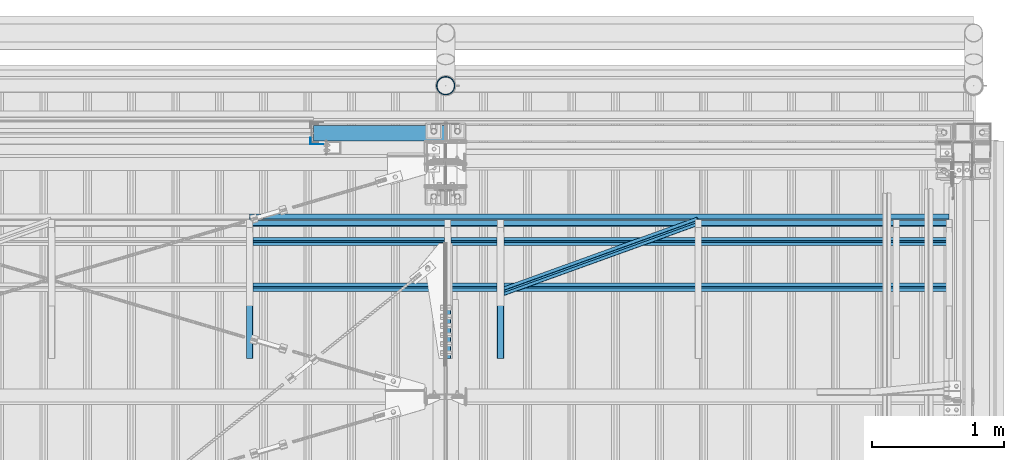
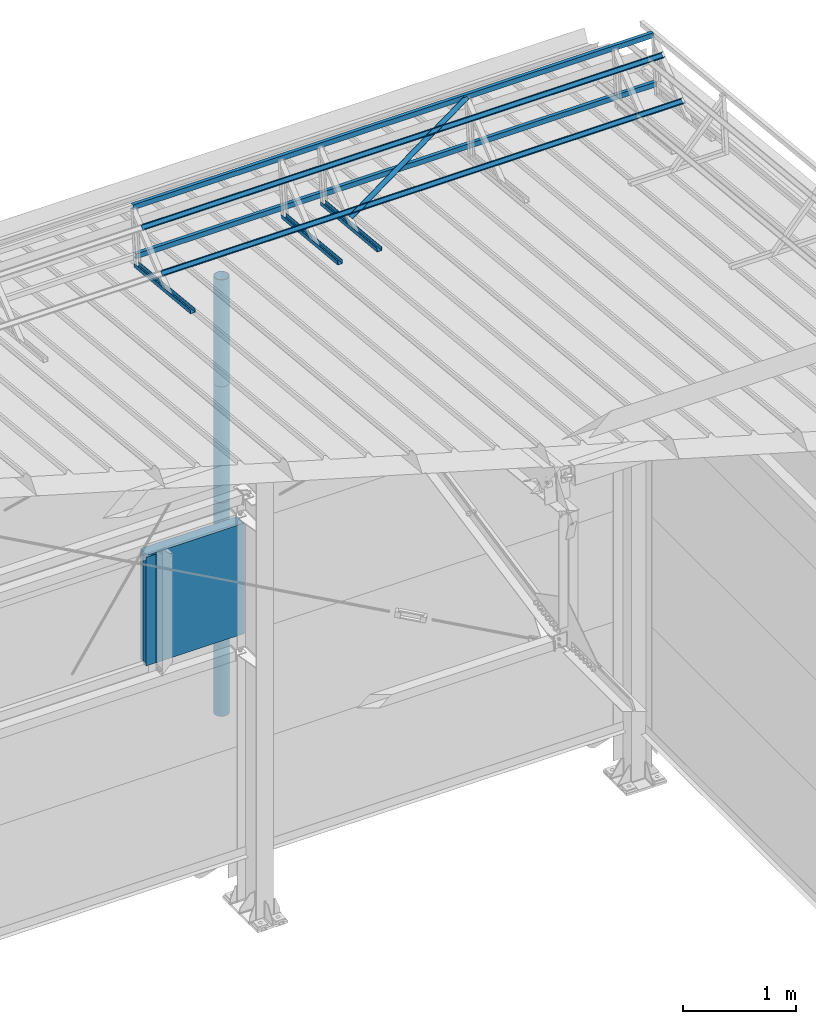
# One storey, part 79 of 709: 14 beams, 14 elements without a shape of their own.
"""IFC4 building model written with IfcOpenShell, lengths in millimetres."""

from ifc_helpers import new_model, si_unit, direction, frame, origin_with_axes, place, context, subcontext, project, spatial, line, indexed_curve, outline, extrude, material, element, aggregate, save


model = new_model("IFC4")

# Units and contexts
model_context = context("Model", 3, precision=0.2, world=origin_with_axes(), true_north=direction((0.0, 1.0)))
body_context = subcontext(model_context, "Body", "Model", "MODEL_VIEW")
ifc_project = project(units=[si_unit("LENGTHUNIT", "METRE", prefix="MILLI"), si_unit("AREAUNIT", "SQUARE_METRE"), si_unit("VOLUMEUNIT", "CUBIC_METRE"), si_unit("MASSUNIT", "GRAM", prefix="KILO"), si_unit("TIMEUNIT", "SECOND"), si_unit("PLANEANGLEUNIT", "RADIAN"), si_unit("SOLIDANGLEUNIT", "STERADIAN"), si_unit("THERMODYNAMICTEMPERATUREUNIT", "DEGREE_CELSIUS"), si_unit("LUMINOUSINTENSITYUNIT", "LUMEN")], contexts=[model_context])

# Site, building, storey
site_placement = place(None, origin_with_axes())
site = spatial("IfcSite", under=ifc_project, at=site_placement, CompositionType="ELEMENT")
building_placement = place(site_placement, origin_with_axes())
building = spatial("IfcBuilding", under=site, at=building_placement, Name="Undefined", CompositionType="ELEMENT")
storey_placement = place(building_placement, origin_with_axes())
storey = spatial("IfcBuildingStorey", under=building, at=storey_placement, Name="Undefined", CompositionType="ELEMENT", Elevation=0.0)

# Assembly, beam
assembly_1_placement = place(storey_placement, frame((46415.0, 21349.29926, 7565.33969), z_axis=(0.0, 0.099503719, 0.9950371902), x_axis=(0.0, -0.9950371902, 0.099503719)))
assembly_1 = element("IfcElementAssembly", 1, at=assembly_1_placement, inside=storey)
ifc_material_1 = material(Name="Steel_Undefined", Category="STEEL")
beam_1_placement = place(assembly_1_placement, origin_with_axes())
beam_1 = element("IfcBeam", 2, at=beam_1_placement, material=ifc_material_1, ObjectType="601", context=body_context, shape_type="SolidModel", body=[
    extrude(outline(indexed_curve([(-20.0, -25.0), (20.0, -25.0), (20.0, -22.5), (-17.5, -22.5), (-17.5, 22.5), (20.0, 22.5), (20.0, 25.0), (-20.0, 25.0)], segments=[line(1, 2, 3, 4, 5, 6, 7, 8, 1)])), frame((0.0, 0.0, 0.0), z_axis=(-1.0, 0.0, 0.0), x_axis=(0.0, 0.0, 1.0)), (0.0, 0.0, -1.0), 1000.0),
])
aggregate(assembly_1, [beam_1])

assembly_2_placement = place(storey_placement, frame((46015.0, 21349.29926, 7565.33969), z_axis=(0.0, 0.099503719, 0.9950371902), x_axis=(0.0, -0.9950371902, 0.099503719)))
assembly_2 = element("IfcElementAssembly", 3, at=assembly_2_placement, inside=storey)
beam_2_placement = place(assembly_2_placement, origin_with_axes())
beam_2 = element("IfcBeam", 4, at=beam_2_placement, material=ifc_material_1, ObjectType="601", context=body_context, shape_type="SolidModel", body=[
    extrude(outline(indexed_curve([(-20.0, -25.0), (20.0, -25.0), (20.0, -22.5), (-17.5, -22.5), (-17.5, 22.5), (20.0, 22.5), (20.0, 25.0), (-20.0, 25.0)], segments=[line(1, 2, 3, 4, 5, 6, 7, 8, 1)])), frame((0.0, 0.0, 0.0), z_axis=(-1.0, 0.0, 0.0), x_axis=(0.0, 0.0, 1.0)), (0.0, 0.0, -1.0), 1000.0),
])
aggregate(assembly_2, [beam_2])

assembly_3_placement = place(storey_placement, frame((49815.0, 21426.91216, 8140.47118), z_axis=(0.0, 0.9950371902, -0.099503719), x_axis=(-1.0, 0.0, 0.0)))
assembly_3 = element("IfcElementAssembly", 5, at=assembly_3_placement, inside=storey)
beam_3_placement = place(assembly_3_placement, origin_with_axes())
beam_3 = element("IfcBeam", 6, at=beam_3_placement, material=ifc_material_1, ObjectType="604", context=body_context, shape_type="SolidModel", body=[
    extrude(outline(indexed_curve([(-20.0, -25.0), (20.0, -25.0), (20.0, -22.5), (-17.5, -22.5), (-17.5, 22.5), (20.0, 22.5), (20.0, 25.0), (-20.0, 25.0)], segments=[line(1, 2, 3, 4, 5, 6, 7, 8, 1)])), frame((0.0, 0.0, 0.0), z_axis=(-1.0, 0.0, 0.0), x_axis=(0.0, 0.0, 1.0)), (0.0, 0.0, -1.0), 5300.0),
])
aggregate(assembly_3, [beam_3])

assembly_4_placement = place(storey_placement, frame((49815.0, 21377.1603, 7642.95259), z_axis=(0.0, 0.9950371902, -0.099503719), x_axis=(-1.0, 0.0, 0.0)))
assembly_4 = element("IfcElementAssembly", 7, at=assembly_4_placement, inside=storey)
beam_4_placement = place(assembly_4_placement, origin_with_axes())
beam_4 = element("IfcBeam", 8, at=beam_4_placement, material=ifc_material_1, ObjectType="604", context=body_context, shape_type="SolidModel", body=[
    extrude(outline(indexed_curve([(-20.0, -25.0), (20.0, -25.0), (20.0, -22.5), (-17.5, -22.5), (-17.5, 22.5), (20.0, 22.5), (20.0, 25.0), (-20.0, 25.0)], segments=[line(1, 2, 3, 4, 5, 6, 7, 8, 1)])), frame((0.0, 0.0, 0.0), z_axis=(-1.0, 0.0, 0.0), x_axis=(0.0, 0.0, 1.0)), (0.0, 0.0, -1.0), 5300.0),
])
aggregate(assembly_4, [beam_4])

assembly_5_placement = place(storey_placement, frame((49815.0, 21239.5552, 8031.29285), z_axis=(0.0, -0.6332377902, 0.7739572992), x_axis=(-1.0, 0.0, 0.0)))
assembly_5 = element("IfcElementAssembly", 9, at=assembly_5_placement, inside=storey)
beam_5_placement = place(assembly_5_placement, origin_with_axes())
beam_5 = element("IfcBeam", 10, at=beam_5_placement, material=ifc_material_1, ObjectType="604", context=body_context, shape_type="SolidModel", body=[
    extrude(outline(indexed_curve([(-20.0, -25.0), (20.0, -25.0), (20.0, -22.5), (-17.5, -22.5), (-17.5, 22.5), (20.0, 22.5), (20.0, 25.0), (-20.0, 25.0)], segments=[line(1, 2, 3, 4, 5, 6, 7, 8, 1)])), frame((0.0, 0.0, 0.0), z_axis=(-1.0, 0.0, 0.0), x_axis=(0.0, 0.0, 1.0)), (0.0, 0.0, -1.0), 5300.0),
])
aggregate(assembly_5, [beam_5])

assembly_6_placement = place(storey_placement, frame((49815.0, 20892.41357, 7747.26788), z_axis=(0.0, -0.6332377902, 0.7739572992), x_axis=(-1.0, 0.0, 0.0)))
assembly_6 = element("IfcElementAssembly", 11, at=assembly_6_placement, inside=storey)
beam_6_placement = place(assembly_6_placement, origin_with_axes())
beam_6 = element("IfcBeam", 12, at=beam_6_placement, material=ifc_material_1, ObjectType="604", context=body_context, shape_type="SolidModel", body=[
    extrude(outline(indexed_curve([(-20.0, -25.0), (20.0, -25.0), (20.0, -22.5), (-17.5, -22.5), (-17.5, 22.5), (20.0, 22.5), (20.0, 25.0), (-20.0, 25.0)], segments=[line(1, 2, 3, 4, 5, 6, 7, 8, 1)])), frame((0.0, 0.0, 0.0), z_axis=(-1.0, 0.0, 0.0), x_axis=(0.0, 0.0, 1.0)), (0.0, 0.0, -1.0), 5300.0),
])
aggregate(assembly_6, [beam_6])

assembly_7_placement = place(storey_placement, frame((47915.0, 21394.34666, 8157.9404), z_axis=(0.0, -0.6332377902, 0.7739572992), x_axis=(-0.9061831398, -0.3272952929, -0.2677870579)))
assembly_7 = element("IfcElementAssembly", 13, at=assembly_7_placement, inside=storey)
beam_7_placement = place(assembly_7_placement, origin_with_axes())
beam_7 = element("IfcBeam", 14, at=beam_7_placement, material=ifc_material_1, ObjectType="605", context=body_context, shape_type="SolidModel", body=[
    extrude(outline(indexed_curve([(-20.0, -25.0), (20.0, -25.0), (20.0, -22.5), (-17.5, -22.5), (-17.5, 22.5), (20.0, 22.5), (20.0, 25.0), (-20.0, 25.0)], segments=[line(1, 2, 3, 4, 5, 6, 7, 8, 1)])), frame((0.0, 0.0, 0.0), z_axis=(-1.0, 0.0, 0.0), x_axis=(0.0, 0.0, 1.0)), (0.0, 0.0, -1.0), 1655.29454),
])
aggregate(assembly_7, [beam_7])

assembly_8_placement = place(storey_placement, frame((44515.0, 21349.29926, 7565.33969), z_axis=(0.0, 0.099503719, 0.9950371902), x_axis=(0.0, -0.9950371902, 0.099503719)))
assembly_8 = element("IfcElementAssembly", 15, at=assembly_8_placement, inside=storey)
beam_8_placement = place(assembly_8_placement, origin_with_axes())
beam_8 = element("IfcBeam", 16, at=beam_8_placement, material=ifc_material_1, ObjectType="601", context=body_context, shape_type="SolidModel", body=[
    extrude(outline(indexed_curve([(-20.0, -25.0), (20.0, -25.0), (20.0, -22.5), (-17.5, -22.5), (-17.5, 22.5), (20.0, 22.5), (20.0, 25.0), (-20.0, 25.0)], segments=[line(1, 2, 3, 4, 5, 6, 7, 8, 1)])), frame((0.0, 0.0, 0.0), z_axis=(-1.0, 0.0, 0.0), x_axis=(0.0, 0.0, 1.0)), (0.0, 0.0, -1.0), 1000.0),
])
aggregate(assembly_8, [beam_8])

assembly_9_placement = place(storey_placement, frame((45000.0, 22060.0, 3275.0), z_axis=(0.0, 0.0, -1.0), x_axis=(1.0, 0.0, 0.0)))
assembly_9 = element("IfcElementAssembly", 17, at=assembly_9_placement, inside=storey)
ifc_material_2 = material(Name="Insulation", Category="Insulation")
beam_9_placement = place(assembly_9_placement, origin_with_axes())
beam_9 = element("IfcBeam", 18, at=beam_9_placement, material=ifc_material_2, ObjectType="P-110", context=body_context, shape_type="SolidModel", body=[
    extrude(outline(indexed_curve([(-595.0, -60.0), (595.0, -60.0), (595.0, 60.0), (-595.0, 60.0)], segments=[line(1, 2, 3, 4, 1)])), frame((0.0, 0.0, 0.0), z_axis=(-1.0, 0.0, 0.0), x_axis=(0.0, 0.0, 1.0)), (0.0, 0.0, -1.0), 990.0),
])
aggregate(assembly_9, [beam_9])

assembly_10_placement = place(storey_placement, frame((44975.0, 22001.0, 3870.0), z_axis=(0.0, -1.0, 0.0), x_axis=(0.0, 0.0, -1.0)))
assembly_10 = element("IfcElementAssembly", 19, at=assembly_10_placement, inside=storey)
beam_10_placement = place(assembly_10_placement, origin_with_axes())
beam_10 = element("IfcBeam", 20, at=beam_10_placement, material=ifc_material_1, context=body_context, shape_type="SolidModel", body=[
    extrude(outline(indexed_curve([(-25.0, -1.0), (25.0, -1.0), (25.0, 99.0), (23.0, 99.0), (23.0, 1.0), (-25.0, 1.0)], segments=[line(1, 2, 3, 4, 5, 6, 1)])), frame((0.0, 0.0, 0.0), z_axis=(-1.0, 0.0, 0.0), x_axis=(0.0, 0.0, 1.0)), (0.0, 0.0, -1.0), 1170.0),
])
aggregate(assembly_10, [beam_10])

assembly_11_placement = place(storey_placement, frame((46000.0, 22420.0, 6276.92297), z_axis=(0.0, -1.0, 0.0), x_axis=(0.0, 0.0, -1.0)))
assembly_11 = element("IfcElementAssembly", 21, at=assembly_11_placement, inside=storey)
beam_11_placement = place(assembly_11_placement, origin_with_axes())
beam_11 = element("IfcBeam", 22, at=beam_11_placement, material=ifc_material_1, ObjectType="614", context=body_context, shape_type="SolidModel", body=[
    extrude(outline(indexed_curve([(70.0, 0.0), (69.61653, 7.31699), (68.47033, 14.55382), (66.57396, 21.63119), (63.94818, 28.47157), (60.62178, 35.0), (56.63119, 41.14497), (52.02014, 46.83914), (46.83914, 52.02014), (41.14497, 56.63119), (35.0, 60.62178), (28.47157, 63.94818), (21.63119, 66.57396), (14.55382, 68.47033), (7.31699, 69.61653), (0.0, 70.0), (-7.31699, 69.61653), (-14.55382, 68.47033), (-21.63119, 66.57396), (-28.47157, 63.94818), (-35.0, 60.62178), (-41.14497, 56.63119), (-46.83914, 52.02014), (-52.02014, 46.83914), (-56.63119, 41.14497), (-60.62178, 35.0), (-63.94818, 28.47157), (-66.57396, 21.63119), (-68.47033, 14.55382), (-69.61653, 7.31699), (-70.0, 0.0), (-69.61653, -7.31699), (-68.47033, -14.55382), (-66.57396, -21.63119), (-63.94818, -28.47157), (-60.62178, -35.0), (-56.63119, -41.14497), (-52.02014, -46.83914), (-46.83914, -52.02014), (-41.14497, -56.63119), (-35.0, -60.62178), (-28.47157, -63.94818), (-21.63119, -66.57396), (-14.55382, -68.47033), (-7.31699, -69.61653), (0.0, -70.0), (7.31699, -69.61653), (14.55382, -68.47033), (21.63119, -66.57396), (28.47157, -63.94818), (35.0, -60.62178), (41.14497, -56.63119), (46.83914, -52.02014), (52.02014, -46.83914), (56.63119, -41.14497), (60.62178, -35.0), (63.94818, -28.47157), (66.57396, -21.63119), (68.47033, -14.55382), (69.61653, -7.31699)], segments=[line(1, 2, 3, 4, 5, 6, 7, 8, 9, 10, 11, 12, 13, 14, 15, 16, 17, 18, 19, 20, 21, 22, 23, 24, 25, 26, 27, 28, 29, 30, 31, 32, 33, 34, 35, 36, 37, 38, 39, 40, 41, 42, 43, 44, 45, 46, 47, 48, 49, 50, 51, 52, 53, 54, 55, 56, 57, 58, 59, 60, 1)]), holes=[indexed_curve([(65.0, 0.0), (64.64392, -6.79435), (63.57959, -13.51426), (61.81867, -20.0861), (59.38045, -26.43788), (56.29165, -32.5), (52.5861, -38.20604), (48.30441, -43.49349), (43.49349, -48.30441), (38.20604, -52.5861), (32.5, -56.29165), (26.43788, -59.38045), (20.0861, -61.81867), (13.51426, -63.57959), (6.79435, -64.64392), (0.0, -65.0), (-6.79435, -64.64392), (-13.51426, -63.57959), (-20.0861, -61.81867), (-26.43788, -59.38045), (-32.5, -56.29165), (-38.20604, -52.5861), (-43.49349, -48.30441), (-48.30441, -43.49349), (-52.5861, -38.20604), (-56.29165, -32.5), (-59.38045, -26.43788), (-61.81867, -20.0861), (-63.57959, -13.51426), (-64.64392, -6.79435), (-65.0, 0.0), (-64.64392, 6.79435), (-63.57959, 13.51426), (-61.81867, 20.0861), (-59.38045, 26.43788), (-56.29165, 32.5), (-52.5861, 38.20604), (-48.30441, 43.49349), (-43.49349, 48.30441), (-38.20604, 52.5861), (-32.5, 56.29165), (-26.43788, 59.38045), (-20.0861, 61.81867), (-13.51426, 63.57959), (-6.79435, 64.64392), (0.0, 65.0), (6.79435, 64.64392), (13.51426, 63.57959), (20.0861, 61.81867), (26.43788, 59.38045), (32.5, 56.29165), (38.20604, 52.5861), (43.49349, 48.30441), (48.30441, 43.49349), (52.5861, 38.20604), (56.29165, 32.5), (59.38045, 26.43788), (61.81867, 20.0861), (63.57959, 13.51426), (64.64392, 6.79435)], segments=[line(1, 2, 3, 4, 5, 6, 7, 8, 9, 10, 11, 12, 13, 14, 15, 16, 17, 18, 19, 20, 21, 22, 23, 24, 25, 26, 27, 28, 29, 30, 31, 32, 33, 34, 35, 36, 37, 38, 39, 40, 41, 42, 43, 44, 45, 46, 47, 48, 49, 50, 51, 52, 53, 54, 55, 56, 57, 58, 59, 60, 1)])]), frame((0.0, 0.0, 0.0), z_axis=(-1.0, 0.0, 0.0), x_axis=(0.0, 0.0, 1.0)), (0.0, 0.0, -1.0), 1250.0),
])
aggregate(assembly_11, [beam_11])

assembly_12_placement = place(storey_placement, frame((46000.0, 22420.0, 5126.92297), z_axis=(0.0, -1.0, 0.0), x_axis=(0.0, 0.0, -1.0)))
assembly_12 = element("IfcElementAssembly", 23, at=assembly_12_placement, inside=storey)
beam_12_placement = place(assembly_12_placement, origin_with_axes())
beam_12 = element("IfcBeam", 24, at=beam_12_placement, material=ifc_material_1, ObjectType="614", context=body_context, shape_type="SolidModel", body=[
    extrude(outline(indexed_curve([(70.0, 0.0), (69.61653, 7.31699), (68.47033, 14.55382), (66.57396, 21.63119), (63.94818, 28.47157), (60.62178, 35.0), (56.63119, 41.14497), (52.02014, 46.83914), (46.83914, 52.02014), (41.14497, 56.63119), (35.0, 60.62178), (28.47157, 63.94818), (21.63119, 66.57396), (14.55382, 68.47033), (7.31699, 69.61653), (0.0, 70.0), (-7.31699, 69.61653), (-14.55382, 68.47033), (-21.63119, 66.57396), (-28.47157, 63.94818), (-35.0, 60.62178), (-41.14497, 56.63119), (-46.83914, 52.02014), (-52.02014, 46.83914), (-56.63119, 41.14497), (-60.62178, 35.0), (-63.94818, 28.47157), (-66.57396, 21.63119), (-68.47033, 14.55382), (-69.61653, 7.31699), (-70.0, 0.0), (-69.61653, -7.31699), (-68.47033, -14.55382), (-66.57396, -21.63119), (-63.94818, -28.47157), (-60.62178, -35.0), (-56.63119, -41.14497), (-52.02014, -46.83914), (-46.83914, -52.02014), (-41.14497, -56.63119), (-35.0, -60.62178), (-28.47157, -63.94818), (-21.63119, -66.57396), (-14.55382, -68.47033), (-7.31699, -69.61653), (0.0, -70.0), (7.31699, -69.61653), (14.55382, -68.47033), (21.63119, -66.57396), (28.47157, -63.94818), (35.0, -60.62178), (41.14497, -56.63119), (46.83914, -52.02014), (52.02014, -46.83914), (56.63119, -41.14497), (60.62178, -35.0), (63.94818, -28.47157), (66.57396, -21.63119), (68.47033, -14.55382), (69.61653, -7.31699)], segments=[line(1, 2, 3, 4, 5, 6, 7, 8, 9, 10, 11, 12, 13, 14, 15, 16, 17, 18, 19, 20, 21, 22, 23, 24, 25, 26, 27, 28, 29, 30, 31, 32, 33, 34, 35, 36, 37, 38, 39, 40, 41, 42, 43, 44, 45, 46, 47, 48, 49, 50, 51, 52, 53, 54, 55, 56, 57, 58, 59, 60, 1)]), holes=[indexed_curve([(65.0, 0.0), (64.64392, -6.79435), (63.57959, -13.51426), (61.81867, -20.0861), (59.38045, -26.43788), (56.29165, -32.5), (52.5861, -38.20604), (48.30441, -43.49349), (43.49349, -48.30441), (38.20604, -52.5861), (32.5, -56.29165), (26.43788, -59.38045), (20.0861, -61.81867), (13.51426, -63.57959), (6.79435, -64.64392), (0.0, -65.0), (-6.79435, -64.64392), (-13.51426, -63.57959), (-20.0861, -61.81867), (-26.43788, -59.38045), (-32.5, -56.29165), (-38.20604, -52.5861), (-43.49349, -48.30441), (-48.30441, -43.49349), (-52.5861, -38.20604), (-56.29165, -32.5), (-59.38045, -26.43788), (-61.81867, -20.0861), (-63.57959, -13.51426), (-64.64392, -6.79435), (-65.0, 0.0), (-64.64392, 6.79435), (-63.57959, 13.51426), (-61.81867, 20.0861), (-59.38045, 26.43788), (-56.29165, 32.5), (-52.5861, 38.20604), (-48.30441, 43.49349), (-43.49349, 48.30441), (-38.20604, 52.5861), (-32.5, 56.29165), (-26.43788, 59.38045), (-20.0861, 61.81867), (-13.51426, 63.57959), (-6.79435, 64.64392), (0.0, 65.0), (6.79435, 64.64392), (13.51426, 63.57959), (20.0861, 61.81867), (26.43788, 59.38045), (32.5, 56.29165), (38.20604, 52.5861), (43.49349, 48.30441), (48.30441, 43.49349), (52.5861, 38.20604), (56.29165, 32.5), (59.38045, 26.43788), (61.81867, 20.0861), (63.57959, 13.51426), (64.64392, 6.79435)], segments=[line(1, 2, 3, 4, 5, 6, 7, 8, 9, 10, 11, 12, 13, 14, 15, 16, 17, 18, 19, 20, 21, 22, 23, 24, 25, 26, 27, 28, 29, 30, 31, 32, 33, 34, 35, 36, 37, 38, 39, 40, 41, 42, 43, 44, 45, 46, 47, 48, 49, 50, 51, 52, 53, 54, 55, 56, 57, 58, 59, 60, 1)])]), frame((0.0, 0.0, 0.0), z_axis=(-1.0, 0.0, 0.0), x_axis=(0.0, 0.0, 1.0)), (0.0, 0.0, -1.0), 1250.0),
])
aggregate(assembly_12, [beam_12])

assembly_13_placement = place(storey_placement, frame((46000.0, 22420.0, 3976.92297), z_axis=(0.0, -1.0, 0.0), x_axis=(0.0, 0.0, -1.0)))
assembly_13 = element("IfcElementAssembly", 25, at=assembly_13_placement, inside=storey)
beam_13_placement = place(assembly_13_placement, origin_with_axes())
beam_13 = element("IfcBeam", 26, at=beam_13_placement, material=ifc_material_1, ObjectType="614", context=body_context, shape_type="SolidModel", body=[
    extrude(outline(indexed_curve([(70.0, 0.0), (69.61653, 7.31699), (68.47033, 14.55382), (66.57396, 21.63119), (63.94818, 28.47157), (60.62178, 35.0), (56.63119, 41.14497), (52.02014, 46.83914), (46.83914, 52.02014), (41.14497, 56.63119), (35.0, 60.62178), (28.47157, 63.94818), (21.63119, 66.57396), (14.55382, 68.47033), (7.31699, 69.61653), (0.0, 70.0), (-7.31699, 69.61653), (-14.55382, 68.47033), (-21.63119, 66.57396), (-28.47157, 63.94818), (-35.0, 60.62178), (-41.14497, 56.63119), (-46.83914, 52.02014), (-52.02014, 46.83914), (-56.63119, 41.14497), (-60.62178, 35.0), (-63.94818, 28.47157), (-66.57396, 21.63119), (-68.47033, 14.55382), (-69.61653, 7.31699), (-70.0, 0.0), (-69.61653, -7.31699), (-68.47033, -14.55382), (-66.57396, -21.63119), (-63.94818, -28.47157), (-60.62178, -35.0), (-56.63119, -41.14497), (-52.02014, -46.83914), (-46.83914, -52.02014), (-41.14497, -56.63119), (-35.0, -60.62178), (-28.47157, -63.94818), (-21.63119, -66.57396), (-14.55382, -68.47033), (-7.31699, -69.61653), (0.0, -70.0), (7.31699, -69.61653), (14.55382, -68.47033), (21.63119, -66.57396), (28.47157, -63.94818), (35.0, -60.62178), (41.14497, -56.63119), (46.83914, -52.02014), (52.02014, -46.83914), (56.63119, -41.14497), (60.62178, -35.0), (63.94818, -28.47157), (66.57396, -21.63119), (68.47033, -14.55382), (69.61653, -7.31699)], segments=[line(1, 2, 3, 4, 5, 6, 7, 8, 9, 10, 11, 12, 13, 14, 15, 16, 17, 18, 19, 20, 21, 22, 23, 24, 25, 26, 27, 28, 29, 30, 31, 32, 33, 34, 35, 36, 37, 38, 39, 40, 41, 42, 43, 44, 45, 46, 47, 48, 49, 50, 51, 52, 53, 54, 55, 56, 57, 58, 59, 60, 1)]), holes=[indexed_curve([(65.0, 0.0), (64.64392, -6.79435), (63.57959, -13.51426), (61.81867, -20.0861), (59.38045, -26.43788), (56.29165, -32.5), (52.5861, -38.20604), (48.30441, -43.49349), (43.49349, -48.30441), (38.20604, -52.5861), (32.5, -56.29165), (26.43788, -59.38045), (20.0861, -61.81867), (13.51426, -63.57959), (6.79435, -64.64392), (0.0, -65.0), (-6.79435, -64.64392), (-13.51426, -63.57959), (-20.0861, -61.81867), (-26.43788, -59.38045), (-32.5, -56.29165), (-38.20604, -52.5861), (-43.49349, -48.30441), (-48.30441, -43.49349), (-52.5861, -38.20604), (-56.29165, -32.5), (-59.38045, -26.43788), (-61.81867, -20.0861), (-63.57959, -13.51426), (-64.64392, -6.79435), (-65.0, 0.0), (-64.64392, 6.79435), (-63.57959, 13.51426), (-61.81867, 20.0861), (-59.38045, 26.43788), (-56.29165, 32.5), (-52.5861, 38.20604), (-48.30441, 43.49349), (-43.49349, 48.30441), (-38.20604, 52.5861), (-32.5, 56.29165), (-26.43788, 59.38045), (-20.0861, 61.81867), (-13.51426, 63.57959), (-6.79435, 64.64392), (0.0, 65.0), (6.79435, 64.64392), (13.51426, 63.57959), (20.0861, 61.81867), (26.43788, 59.38045), (32.5, 56.29165), (38.20604, 52.5861), (43.49349, 48.30441), (48.30441, 43.49349), (52.5861, 38.20604), (56.29165, 32.5), (59.38045, 26.43788), (61.81867, 20.0861), (63.57959, 13.51426), (64.64392, 6.79435)], segments=[line(1, 2, 3, 4, 5, 6, 7, 8, 9, 10, 11, 12, 13, 14, 15, 16, 17, 18, 19, 20, 21, 22, 23, 24, 25, 26, 27, 28, 29, 30, 31, 32, 33, 34, 35, 36, 37, 38, 39, 40, 41, 42, 43, 44, 45, 46, 47, 48, 49, 50, 51, 52, 53, 54, 55, 56, 57, 58, 59, 60, 1)])]), frame((0.0, 0.0, 0.0), z_axis=(-1.0, 0.0, 0.0), x_axis=(0.0, 0.0, 1.0)), (0.0, 0.0, -1.0), 1250.0),
])
aggregate(assembly_13, [beam_13])

assembly_14_placement = place(storey_placement, frame((46000.0, 22420.0, 2826.92297), z_axis=(0.0, -1.0, 0.0), x_axis=(0.0, 0.0, -1.0)))
assembly_14 = element("IfcElementAssembly", 27, at=assembly_14_placement, inside=storey)
beam_14_placement = place(assembly_14_placement, origin_with_axes())
beam_14 = element("IfcBeam", 28, at=beam_14_placement, material=ifc_material_1, ObjectType="614", context=body_context, shape_type="SolidModel", body=[
    extrude(outline(indexed_curve([(70.0, 0.0), (69.61653, 7.31699), (68.47033, 14.55382), (66.57396, 21.63119), (63.94818, 28.47157), (60.62178, 35.0), (56.63119, 41.14497), (52.02014, 46.83914), (46.83914, 52.02014), (41.14497, 56.63119), (35.0, 60.62178), (28.47157, 63.94818), (21.63119, 66.57396), (14.55382, 68.47033), (7.31699, 69.61653), (0.0, 70.0), (-7.31699, 69.61653), (-14.55382, 68.47033), (-21.63119, 66.57396), (-28.47157, 63.94818), (-35.0, 60.62178), (-41.14497, 56.63119), (-46.83914, 52.02014), (-52.02014, 46.83914), (-56.63119, 41.14497), (-60.62178, 35.0), (-63.94818, 28.47157), (-66.57396, 21.63119), (-68.47033, 14.55382), (-69.61653, 7.31699), (-70.0, 0.0), (-69.61653, -7.31699), (-68.47033, -14.55382), (-66.57396, -21.63119), (-63.94818, -28.47157), (-60.62178, -35.0), (-56.63119, -41.14497), (-52.02014, -46.83914), (-46.83914, -52.02014), (-41.14497, -56.63119), (-35.0, -60.62178), (-28.47157, -63.94818), (-21.63119, -66.57396), (-14.55382, -68.47033), (-7.31699, -69.61653), (0.0, -70.0), (7.31699, -69.61653), (14.55382, -68.47033), (21.63119, -66.57396), (28.47157, -63.94818), (35.0, -60.62178), (41.14497, -56.63119), (46.83914, -52.02014), (52.02014, -46.83914), (56.63119, -41.14497), (60.62178, -35.0), (63.94818, -28.47157), (66.57396, -21.63119), (68.47033, -14.55382), (69.61653, -7.31699)], segments=[line(1, 2, 3, 4, 5, 6, 7, 8, 9, 10, 11, 12, 13, 14, 15, 16, 17, 18, 19, 20, 21, 22, 23, 24, 25, 26, 27, 28, 29, 30, 31, 32, 33, 34, 35, 36, 37, 38, 39, 40, 41, 42, 43, 44, 45, 46, 47, 48, 49, 50, 51, 52, 53, 54, 55, 56, 57, 58, 59, 60, 1)]), holes=[indexed_curve([(65.0, 0.0), (64.64392, -6.79435), (63.57959, -13.51426), (61.81867, -20.0861), (59.38045, -26.43788), (56.29165, -32.5), (52.5861, -38.20604), (48.30441, -43.49349), (43.49349, -48.30441), (38.20604, -52.5861), (32.5, -56.29165), (26.43788, -59.38045), (20.0861, -61.81867), (13.51426, -63.57959), (6.79435, -64.64392), (0.0, -65.0), (-6.79435, -64.64392), (-13.51426, -63.57959), (-20.0861, -61.81867), (-26.43788, -59.38045), (-32.5, -56.29165), (-38.20604, -52.5861), (-43.49349, -48.30441), (-48.30441, -43.49349), (-52.5861, -38.20604), (-56.29165, -32.5), (-59.38045, -26.43788), (-61.81867, -20.0861), (-63.57959, -13.51426), (-64.64392, -6.79435), (-65.0, 0.0), (-64.64392, 6.79435), (-63.57959, 13.51426), (-61.81867, 20.0861), (-59.38045, 26.43788), (-56.29165, 32.5), (-52.5861, 38.20604), (-48.30441, 43.49349), (-43.49349, 48.30441), (-38.20604, 52.5861), (-32.5, 56.29165), (-26.43788, 59.38045), (-20.0861, 61.81867), (-13.51426, 63.57959), (-6.79435, 64.64392), (0.0, 65.0), (6.79435, 64.64392), (13.51426, 63.57959), (20.0861, 61.81867), (26.43788, 59.38045), (32.5, 56.29165), (38.20604, 52.5861), (43.49349, 48.30441), (48.30441, 43.49349), (52.5861, 38.20604), (56.29165, 32.5), (59.38045, 26.43788), (61.81867, 20.0861), (63.57959, 13.51426), (64.64392, 6.79435)], segments=[line(1, 2, 3, 4, 5, 6, 7, 8, 9, 10, 11, 12, 13, 14, 15, 16, 17, 18, 19, 20, 21, 22, 23, 24, 25, 26, 27, 28, 29, 30, 31, 32, 33, 34, 35, 36, 37, 38, 39, 40, 41, 42, 43, 44, 45, 46, 47, 48, 49, 50, 51, 52, 53, 54, 55, 56, 57, 58, 59, 60, 1)])]), frame((0.0, 0.0, 0.0), z_axis=(-1.0, 0.0, 0.0), x_axis=(0.0, 0.0, 1.0)), (0.0, 0.0, -1.0), 1250.0),
])
aggregate(assembly_14, [beam_14])

save(model, "model.ifc")
